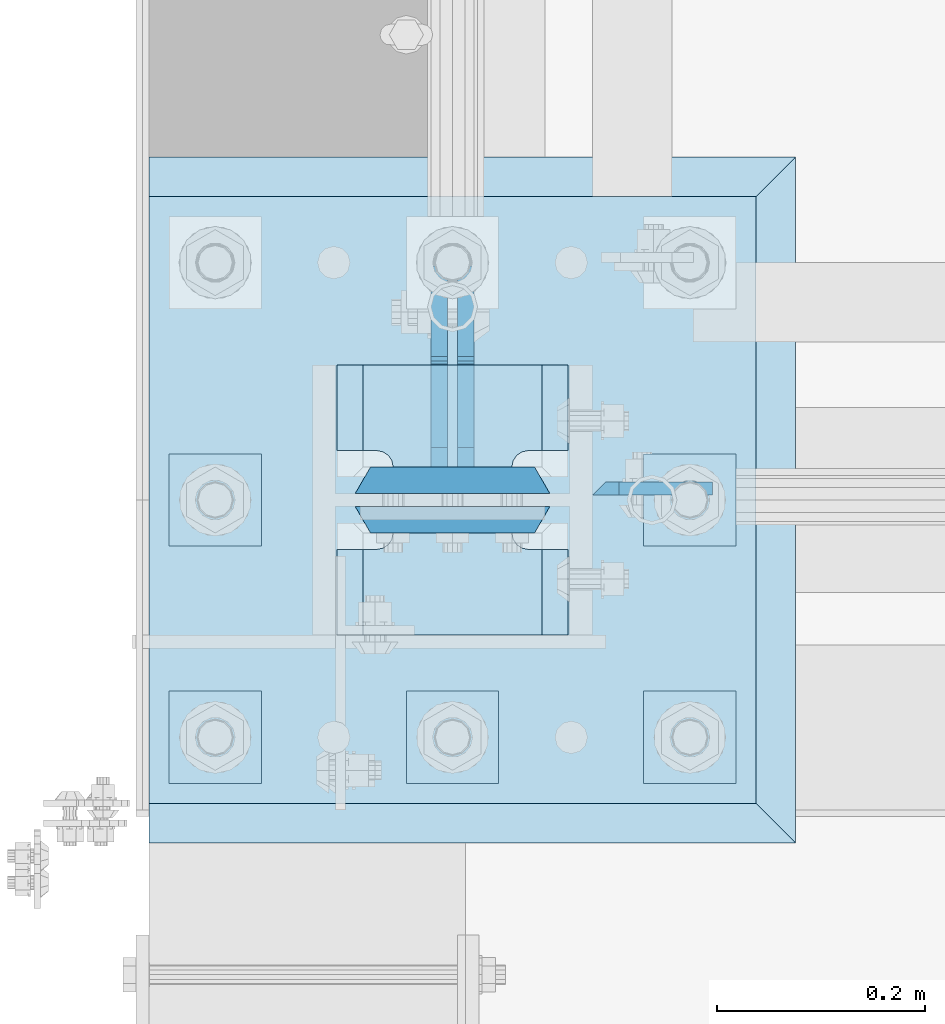
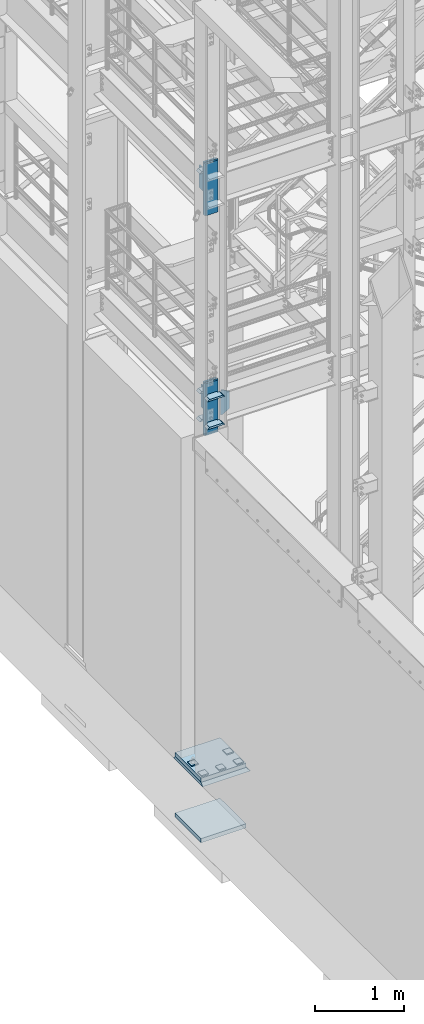
# One storey, part 1422 of 1876: 20 plates, 3 elements without a shape of their own.
"""IFC2X3 building model written with IfcOpenShell, lengths in millimetres."""

from ifc_helpers import new_model, si_unit, frame, origin_with_axes, place, context, subcontext, project, spatial, faceted_brep, material, type_object, element, aggregate, save


model = new_model("IFC2X3")

# Units and contexts
model_context = context("Model", 3, precision=1e-05, world=origin_with_axes())
body_context = subcontext(model_context, "Body", "Model", "MODEL_VIEW")
ifc_project = project(units=[si_unit("LENGTHUNIT", "METRE", prefix="MILLI"), si_unit("AREAUNIT", "SQUARE_METRE"), si_unit("VOLUMEUNIT", "CUBIC_METRE"), si_unit("MASSUNIT", "GRAM", prefix="KILO"), si_unit("TIMEUNIT", "SECOND"), si_unit("PLANEANGLEUNIT", "RADIAN"), si_unit("SOLIDANGLEUNIT", "STERADIAN"), si_unit("THERMODYNAMICTEMPERATUREUNIT", "DEGREE_CELSIUS"), si_unit("LUMINOUSINTENSITYUNIT", "LUMEN")], contexts=[model_context])

# Site, building, storey
site_placement = place(None, origin_with_axes())
site = spatial("IfcSite", under=ifc_project, at=site_placement, CompositionType="ELEMENT")
building_placement = place(site_placement, origin_with_axes())
building = spatial("IfcBuilding", under=site, at=building_placement, Name="Undefined", CompositionType="ELEMENT")
storey_placement = place(building_placement, origin_with_axes())
storey = spatial("IfcBuildingStorey", under=building, at=storey_placement, Name="Undefined", CompositionType="ELEMENT", Elevation=0.0)

# Assembly, plates
assembly_1_placement = place(storey_placement, origin_with_axes())
assembly_1 = element("IfcElementAssembly", 1, at=assembly_1_placement, inside=storey, Name="COLUMN", AssemblyPlace="NOTDEFINED", PredefinedType="RIGID_FRAME")
ifc_material_1 = material(Name="STEEL/A572-50")
plate_type_1 = type_object("IfcPlateType", PredefinedType="NOTDEFINED")
plate_1_placement = place(assembly_1_placement, frame((134.9375, -7100.88799991608, 5094.2875), z_axis=(1.0, 0.0, 0.0), x_axis=(0.0, 0.0, -1.0)))
plate_1 = element("IfcPlate", 2, at=plate_1_placement, type_object=plate_type_1, material=ifc_material_1, Name="PLATE", context=body_context, shape_type="Brep", body=[
    faceted_brep([(0.0, -6.35000000000036, 0.0), (-1.06936913171421e-12, 6.34999999999945, 12.699999332428), (336.549987792969, 6.35000000000036, 12.7), (336.549987792969, -6.35000000000036, 0.0), (336.550000000001, -6.35000000000036, 25.4000000000005), (336.549987792969, 6.35000000000036, 25.4000000000005), (284.53616791736, 6.35000000000036, 115.490600585938), (284.53616791736, -6.35000000000036, 115.490600307004), (52.0138320922852, -6.35000000000036, 115.490599060059), (52.0138320922852, 6.35000000000036, 115.490600585938), (0.0, 6.35000000000036, 25.4000000000005), (0.0, -6.35000000000036, 25.4000000000005)], [[[0, 1, 2, 3]], [[4, 5, 6, 7]], [[8, 9, 10, 11]], [[11, 10, 1, 0]], [[8, 11, 0, 3, 4, 7]], [[9, 8, 7, 6]], [[10, 9, 6, 5, 2, 1]], [[5, 4, 3, 2]]]),
])
plate_type_2 = type_object("IfcPlateType", PredefinedType="NOTDEFINED")
plate_2_placement = place(assembly_1_placement, frame((111.125, -6981.825, 8140.7), z_axis=(-1.0, 0.0, 0.0), x_axis=(0.0, -1.0, 0.0)))
plate_2 = element("IfcPlate", 3, at=plate_2_placement, type_object=plate_type_2, material=ifc_material_1, Name="PLATE", context=body_context, shape_type="Brep", body=[
    faceted_brep([(82.5500030517578, -12.7000000000007, 222.25), (82.5500030517578, 12.7000000000007, 197.150000002177), (0.0, 12.7000000000007, 197.150000002177), (0.0, -12.7000000000007, 222.25), (82.5500030517578, 12.7000000000007, 25.0999999978233), (82.5500030517578, -12.7000000000007, 0.0), (0.0, -12.6999999999998, 0.0), (0.0, 12.7000000000007, 25.0999999978233), (82.5500030517578, 12.7000000000007, 38.0999984741211), (82.5500030517578, -12.7000000000007, 38.0999984741211), (83.7584154731412, -12.7000000000007, 44.1750979629169), (83.7584154731412, 12.7000000000007, 44.1750979629169), (87.1996829004211, -12.7000000000007, 49.3253186254576), (87.1996829004211, 12.7000000000007, 49.3253186254576), (92.349903562962, -12.7000000000007, 52.7665860527377), (92.349903562962, 12.7000000000007, 52.7665860527377), (98.4250030517578, -12.7000000000007, 53.9749984741211), (98.4250030517578, 12.7000000000007, 53.9749984741211), (98.4250030517578, -12.7000000000007, 168.275001525879), (98.4250030517578, 12.7000000000007, 168.275001525879), (92.349903562962, -12.7000000000007, 169.483413947262), (92.349903562962, 12.7000000000007, 169.483413947262), (87.1996829004211, -12.7000000000007, 172.924681374543), (87.1996829004211, 12.7000000000007, 172.924681374543), (83.7584154731412, -12.7000000000007, 178.074902037083), (83.7584154731412, 12.7000000000007, 178.074902037083), (82.5500030517578, -12.7000000000007, 184.150001525879), (82.5500030517578, 12.7000000000007, 184.150001525879)], [[[0, 1, 2, 3]], [[4, 5, 6, 7]], [[8, 9, 5, 4]], [[10, 9, 8, 11]], [[12, 10, 11, 13]], [[14, 12, 13, 15]], [[16, 14, 15, 17]], [[18, 16, 17, 19]], [[20, 18, 19, 21]], [[22, 20, 21, 23]], [[24, 22, 23, 25]], [[26, 24, 25, 27]], [[6, 5, 9, 10, 12, 14, 16, 18, 20, 22, 24, 26, 0, 3]], [[7, 6, 3, 2]], [[27, 25, 23, 21, 19, 17, 15, 13, 11, 8, 4, 7, 2, 1]], [[26, 27, 1, 0]]]),
])
plate_3_placement = place(assembly_1_placement, frame((111.125, -7143.75, 4733.92501220703), z_axis=(-1.0, 0.0, 0.0), x_axis=(0.0, -1.0, 0.0)))
plate_3 = element("IfcPlate", 4, at=plate_3_placement, type_object=plate_type_2, material=ifc_material_1, Name="PLATE", context=body_context, shape_type="Brep", body=[
    faceted_brep([(98.4250030517578, -12.7000000000007, 222.25), (98.4250030517578, 12.7000000000007, 197.150000002177), (15.875, 12.7000000000007, 197.150000002177), (15.875, -12.7000000000007, 222.25), (14.6665875786157, -12.7000000000007, 178.074902037082), (15.875, -12.7000000000007, 184.150001525879), (15.875, 12.7000000000007, 184.150001525879), (14.6665875786157, 12.7000000000007, 178.074902037082), (11.2253201513358, -12.7000000000007, 172.924681374541), (11.2253201513358, 12.7000000000007, 172.924681374541), (6.07509948879488, -12.7000000000007, 169.483413947261), (6.07509948879488, 12.7000000000007, 169.483413947261), (0.0, -12.7000000000007, 168.275001525879), (0.0, 12.7000000000007, 168.275001525879), (0.0, -12.7000000000007, 53.9749984741211), (0.0, 12.7000000000007, 53.9749984741211), (6.07509948879579, -12.7000000000007, 52.7665860527377), (6.07509948879579, 12.7000000000007, 52.7665860527377), (11.2253201513367, -12.7000000000007, 49.3253186254576), (11.2253201513367, 12.7000000000007, 49.3253186254576), (14.6665875786166, -12.7000000000007, 44.1750979629169), (14.6665875786166, 12.7000000000007, 44.1750979629169), (15.875, -12.7000000000007, 38.0999984741211), (15.875, 12.7000000000007, 38.0999984741211), (15.875, 12.7000000000007, 25.0999999978233), (15.875, -12.7000000000007, 0.0), (98.4250030517578, 12.7000000000007, 25.0999999978233), (98.4250030517578, -12.7000000000007, 0.0)], [[[0, 1, 2, 3]], [[4, 5, 6, 7]], [[8, 4, 7, 9]], [[10, 8, 9, 11]], [[12, 10, 11, 13]], [[14, 12, 13, 15]], [[16, 14, 15, 17]], [[18, 16, 17, 19]], [[20, 18, 19, 21]], [[22, 20, 21, 23]], [[22, 23, 24, 25]], [[26, 27, 25, 24]], [[5, 4, 8, 10, 12, 14, 16, 18, 20, 22, 25, 27, 0, 3]], [[6, 5, 3, 2]], [[26, 24, 23, 21, 19, 17, 15, 13, 11, 9, 7, 6, 2, 1]], [[27, 26, 1, 0]]]),
])
plate_4_placement = place(assembly_1_placement, frame((111.125, -7143.75, 5118.1), z_axis=(-1.0, 0.0, 0.0), x_axis=(0.0, -1.0, 0.0)))
plate_4 = element("IfcPlate", 5, at=plate_4_placement, type_object=plate_type_2, material=ifc_material_1, Name="PLATE", context=body_context, shape_type="Brep", body=[
    faceted_brep([(98.4250030517578, -12.7000000000007, 222.25), (98.4250030517578, 12.7000000000007, 197.150000002177), (15.875, 12.7000000000007, 197.150000002177), (15.875, -12.7000000000007, 222.25), (14.6665875786157, -12.7000000000007, 178.074902037082), (15.875, -12.7000000000007, 184.150001525879), (15.875, 12.7000000000007, 184.150001525879), (14.6665875786157, 12.7000000000007, 178.074902037082), (11.2253201513358, -12.7000000000007, 172.924681374541), (11.2253201513358, 12.7000000000007, 172.924681374541), (6.07509948879488, -12.7000000000007, 169.483413947261), (6.07509948879488, 12.7000000000007, 169.483413947261), (0.0, -12.7000000000007, 168.275001525879), (0.0, 12.7000000000007, 168.275001525879), (0.0, -12.7000000000007, 53.9749984741211), (0.0, 12.7000000000007, 53.9749984741211), (6.07509948879579, -12.7000000000007, 52.7665860527377), (6.07509948879579, 12.7000000000007, 52.7665860527377), (11.2253201513367, -12.7000000000007, 49.3253186254576), (11.2253201513367, 12.7000000000007, 49.3253186254576), (14.6665875786166, -12.7000000000007, 44.1750979629169), (14.6665875786166, 12.7000000000007, 44.1750979629169), (15.875, -12.7000000000007, 38.0999984741211), (15.875, 12.7000000000007, 38.0999984741211), (15.875, 12.7000000000007, 25.0999999978233), (15.875, -12.7000000000007, 0.0), (98.4250030517578, 12.7000000000007, 25.0999999978233), (98.4250030517578, -12.7000000000007, 0.0)], [[[0, 1, 2, 3]], [[4, 5, 6, 7]], [[8, 4, 7, 9]], [[10, 8, 9, 11]], [[12, 10, 11, 13]], [[14, 12, 13, 15]], [[16, 14, 15, 17]], [[18, 16, 17, 19]], [[20, 18, 19, 21]], [[22, 20, 21, 23]], [[22, 23, 24, 25]], [[26, 27, 25, 24]], [[5, 4, 8, 10, 12, 14, 16, 18, 20, 22, 25, 27, 0, 3]], [[6, 5, 3, 2]], [[26, 24, 23, 21, 19, 17, 15, 13, 11, 9, 7, 6, 2, 1]], [[27, 26, 1, 0]]]),
])
plate_5_placement = place(assembly_1_placement, frame((111.125, -6981.825, 4733.92501220703), z_axis=(-1.0, 0.0, 0.0), x_axis=(0.0, -1.0, 0.0)))
plate_5 = element("IfcPlate", 6, at=plate_5_placement, type_object=plate_type_2, material=ifc_material_1, Name="PLATE", context=body_context, shape_type="Brep", body=[
    faceted_brep([(82.5500030517578, -12.7000000000007, 222.25), (82.5500030517578, 12.7000000000007, 197.150000002177), (0.0, 12.7000000000007, 197.150000002177), (0.0, -12.7000000000007, 222.25), (82.5500030517578, 12.7000000000007, 25.0999999978233), (82.5500030517578, -12.7000000000007, 0.0), (0.0, -12.6999999999998, 0.0), (0.0, 12.7000000000007, 25.0999999978233), (82.5500030517578, 12.7000000000007, 38.0999984741211), (82.5500030517578, -12.7000000000007, 38.0999984741211), (83.7584154731412, -12.7000000000007, 44.1750979629169), (83.7584154731412, 12.7000000000007, 44.1750979629169), (87.1996829004211, -12.7000000000007, 49.3253186254576), (87.1996829004211, 12.7000000000007, 49.3253186254576), (92.349903562962, -12.7000000000007, 52.7665860527377), (92.349903562962, 12.7000000000007, 52.7665860527377), (98.4250030517578, -12.7000000000007, 53.9749984741211), (98.4250030517578, 12.7000000000007, 53.9749984741211), (98.4250030517578, -12.7000000000007, 168.275001525879), (98.4250030517578, 12.7000000000007, 168.275001525879), (92.349903562962, -12.7000000000007, 169.483413947262), (92.349903562962, 12.7000000000007, 169.483413947262), (87.1996829004211, -12.7000000000007, 172.924681374543), (87.1996829004211, 12.7000000000007, 172.924681374543), (83.7584154731412, -12.7000000000007, 178.074902037083), (83.7584154731412, 12.7000000000007, 178.074902037083), (82.5500030517578, -12.7000000000007, 184.150001525879), (82.5500030517578, 12.7000000000007, 184.150001525879)], [[[0, 1, 2, 3]], [[4, 5, 6, 7]], [[8, 9, 5, 4]], [[10, 9, 8, 11]], [[12, 10, 11, 13]], [[14, 12, 13, 15]], [[16, 14, 15, 17]], [[18, 16, 17, 19]], [[20, 18, 19, 21]], [[22, 20, 21, 23]], [[24, 22, 23, 25]], [[26, 24, 25, 27]], [[6, 5, 9, 10, 12, 14, 16, 18, 20, 22, 24, 26, 0, 3]], [[7, 6, 3, 2]], [[27, 25, 23, 21, 19, 17, 15, 13, 11, 8, 4, 7, 2, 1]], [[26, 27, 1, 0]]]),
])
plate_6_placement = place(assembly_1_placement, frame((111.125, -6981.825, 5118.1), z_axis=(-1.0, 0.0, 0.0), x_axis=(0.0, -1.0, 0.0)))
plate_6 = element("IfcPlate", 7, at=plate_6_placement, type_object=plate_type_2, material=ifc_material_1, Name="PLATE", context=body_context, shape_type="Brep", body=[
    faceted_brep([(82.5500030517578, -12.7000000000007, 222.25), (82.5500030517578, 12.7000000000007, 197.150000002177), (0.0, 12.7000000000007, 197.150000002177), (0.0, -12.7000000000007, 222.25), (82.5500030517578, 12.7000000000007, 25.0999999978233), (82.5500030517578, -12.7000000000007, 0.0), (0.0, -12.6999999999998, 0.0), (0.0, 12.7000000000007, 25.0999999978233), (82.5500030517578, 12.7000000000007, 38.0999984741211), (82.5500030517578, -12.7000000000007, 38.0999984741211), (83.7584154731412, -12.7000000000007, 44.1750979629169), (83.7584154731412, 12.7000000000007, 44.1750979629169), (87.1996829004211, -12.7000000000007, 49.3253186254576), (87.1996829004211, 12.7000000000007, 49.3253186254576), (92.349903562962, -12.7000000000007, 52.7665860527377), (92.349903562962, 12.7000000000007, 52.7665860527377), (98.4250030517578, -12.7000000000007, 53.9749984741211), (98.4250030517578, 12.7000000000007, 53.9749984741211), (98.4250030517578, -12.7000000000007, 168.275001525879), (98.4250030517578, 12.7000000000007, 168.275001525879), (92.349903562962, -12.7000000000007, 169.483413947262), (92.349903562962, 12.7000000000007, 169.483413947262), (87.1996829004211, -12.7000000000007, 172.924681374543), (87.1996829004211, 12.7000000000007, 172.924681374543), (83.7584154731412, -12.7000000000007, 178.074902037083), (83.7584154731412, 12.7000000000007, 178.074902037083), (82.5500030517578, -12.7000000000007, 184.150001525879), (82.5500030517578, 12.7000000000007, 184.150001525879)], [[[0, 1, 2, 3]], [[4, 5, 6, 7]], [[8, 9, 5, 4]], [[10, 9, 8, 11]], [[12, 10, 11, 13]], [[14, 12, 13, 15]], [[16, 14, 15, 17]], [[18, 16, 17, 19]], [[20, 18, 19, 21]], [[22, 20, 21, 23]], [[24, 22, 23, 25]], [[26, 24, 25, 27]], [[6, 5, 9, 10, 12, 14, 16, 18, 20, 22, 24, 26, 0, 3]], [[7, 6, 3, 2]], [[27, 25, 23, 21, 19, 17, 15, 13, 11, 8, 4, 7, 2, 1]], [[26, 27, 1, 0]]]),
])
ifc_material_2 = material(Name="STEEL/A572-GR.50")
plate_type_3 = type_object("IfcPlateType", PredefinedType="NOTDEFINED")
plate_7_placement = place(assembly_1_placement, frame((-93.6625, -7131.05, 8305.8), z_axis=(1.0, 0.0, 0.0), x_axis=(0.0, 0.0, -1.0)))
plate_7 = element("IfcPlate", 8, at=plate_7_placement, type_object=plate_type_3, material=ifc_material_2, Name="PLATE", context=body_context, shape_type="Brep", body=[
    faceted_brep([(0.0, -12.6999999999998, 172.660303166218), (714.375, -12.6999999999998, 172.660303166232), (714.375, 12.6999999999998, 187.324996948242), (0.0, 12.6999999999998, 187.324996948242), (714.375, -12.6999999999998, 14.6646968337647), (714.375, 12.6999999999998, 0.0), (0.0, 12.6999999999998, 0.0), (0.0, -12.6999999999998, 14.6646968337648)], [[[0, 1, 2, 3]], [[2, 1, 4, 5]], [[3, 2, 5, 6]], [[0, 3, 6, 7]], [[1, 0, 7, 4]], [[6, 5, 4, 7]]]),
])
plate_8_placement = place(assembly_1_placement, frame((-93.6625, -7092.95, 8305.8), z_axis=(1.0, 0.0, 0.0), x_axis=(0.0, 0.0, -1.0)))
plate_8 = element("IfcPlate", 9, at=plate_8_placement, type_object=plate_type_3, material=ifc_material_2, Name="PLATE", context=body_context, shape_type="Brep", body=[
    faceted_brep([(0.0, 12.6999999999998, 172.66030316161), (0.0, -12.6999999999998, 187.324996948242), (714.375, -12.6999999999998, 187.324996948242), (714.375, 12.6999999999998, 172.660303161603), (714.375, 12.6999999999998, 14.6646968384017), (0.0, 12.6999999999998, 14.6646968383725), (0.0, -12.6999999999998, 0.0), (714.375, -12.6999999999998, 0.0)], [[[0, 1, 2, 3]], [[0, 3, 4, 5]], [[1, 0, 5, 6]], [[2, 1, 6, 7]], [[3, 2, 7, 4]], [[6, 5, 4, 7]]]),
])
plate_9_placement = place(assembly_1_placement, frame((-93.6625, -7131.05, 5283.2), z_axis=(1.0, 0.0, 0.0), x_axis=(0.0, 0.0, -1.0)))
plate_9 = element("IfcPlate", 10, at=plate_9_placement, type_object=plate_type_3, material=ifc_material_2, Name="PLATE", context=body_context, shape_type="Brep", body=[
    faceted_brep([(0.0, -12.6999999999998, 172.660303166218), (714.375, -12.6999999999998, 172.660303166232), (714.375, 12.6999999999998, 187.324996948242), (0.0, 12.6999999999998, 187.324996948242), (714.375, -12.6999999999998, 14.6646968337647), (714.375, 12.6999999999998, 0.0), (0.0, 12.6999999999998, 0.0), (0.0, -12.6999999999998, 14.6646968337648)], [[[0, 1, 2, 3]], [[2, 1, 4, 5]], [[3, 2, 5, 6]], [[0, 3, 6, 7]], [[1, 0, 7, 4]], [[6, 5, 4, 7]]]),
])
plate_10_placement = place(assembly_1_placement, frame((-93.6625, -7092.95, 5283.2), z_axis=(1.0, 0.0, 0.0), x_axis=(0.0, 0.0, -1.0)))
plate_10 = element("IfcPlate", 11, at=plate_10_placement, type_object=plate_type_3, material=ifc_material_2, Name="PLATE", context=body_context, shape_type="Brep", body=[
    faceted_brep([(0.0, 12.6999999999998, 172.66030316161), (0.0, -12.6999999999998, 187.324996948242), (714.375, -12.6999999999998, 187.324996948242), (714.375, 12.6999999999998, 172.660303161603), (714.375, 12.6999999999998, 14.6646968384017), (0.0, 12.6999999999998, 14.6646968383725), (0.0, -12.6999999999998, 0.0), (714.375, -12.6999999999998, 0.0)], [[[0, 1, 2, 3]], [[0, 3, 4, 5]], [[1, 0, 5, 6]], [[2, 1, 6, 7]], [[3, 2, 7, 4]], [[6, 5, 4, 7]]]),
])
plate_type_4 = type_object("IfcPlateType", PredefinedType="NOTDEFINED")
plate_11_placement = place(assembly_1_placement, frame((-12.6995000839233, -7080.25, 8128.0), z_axis=(0.0, 1.0, 0.0), x_axis=(0.0, 0.0, -1.0)))
plate_11 = element("IfcPlate", 12, at=plate_11_placement, type_object=plate_type_4, material=ifc_material_1, Name="PLATE", context=body_context, shape_type="Brep", body=[
    faceted_brep([(4.8600795180455, -7.9375, 99.3922299225887), (4.8600795180455, 7.9375, 99.3922299225887), (0.0, 7.9375, 98.4255000000012), (0.0, -7.9375, 98.4255000000012), (8.98025598619915, -7.9375, 102.145243823067), (8.98025598619915, 7.9375, 102.145243823067), (11.7332698866776, -7.9375, 106.265420291221), (11.7332698866776, 7.9375, 106.265420291221), (12.6999998092651, -7.9375, 111.125499809266), (12.6999998092651, 7.9375, 111.125499809266), (12.6999998092651, -7.9375, 193.675500000001), (12.7000000839216, 7.9375, 193.675003051758), (19.0499992370605, -7.9375, 0.0), (0.0, -7.9375, 19.0499992370605), (0.0, 7.9375, 19.0499992370605), (19.0499992370605, 7.9375, 0.0), (339.724994659424, -7.9375, 0.0), (339.724994659424, 7.9375, 0.0), (358.774993896484, -7.9375, 19.0499992370605), (358.774993896484, 7.9375, 19.0499992370605), (358.774993896484, 7.9375, 98.4255000000012), (358.775, -7.9375, 98.4255000000012), (330.199986839294, 7.9375, 98.4255000000012), (330.199986839294, -7.9375, 98.4255000000012), (325.339907321249, 7.9375, 99.3922299225887), (325.339907321249, -7.9375, 99.3922299225887), (321.219730853095, 7.9375, 102.145243823067), (321.219730853095, -7.9375, 102.145243823067), (318.466716952616, 7.9375, 106.265420291221), (318.466716952616, -7.9375, 106.265420291221), (317.499987030029, 7.9375, 111.125499809266), (317.499987030029, -7.9375, 111.125499809266), (317.499987030027, -7.9375, 193.675002687786), (317.499987030027, 7.9375, 193.675003051758)], [[[0, 1, 2, 3]], [[4, 5, 1, 0]], [[6, 7, 5, 4]], [[8, 9, 7, 6]], [[10, 11, 9, 8]], [[12, 13, 14, 15]], [[16, 12, 15, 17]], [[18, 16, 17, 19]], [[18, 19, 20, 21]], [[21, 20, 22, 23]], [[23, 22, 24, 25]], [[25, 24, 26, 27]], [[27, 26, 28, 29]], [[29, 28, 30, 31]], [[32, 31, 30, 33]], [[6, 4, 0, 3, 13, 12, 16, 18, 21, 23, 25, 27, 29, 31, 32, 10, 8]], [[14, 13, 3, 2]], [[33, 30, 28, 26, 24, 22, 20, 19, 17, 15, 14, 2, 1, 5, 7, 9, 11]], [[32, 33, 11, 10]]]),
])
plate_12_placement = place(assembly_1_placement, frame((12.6995000839233, -7080.25, 5105.4), z_axis=(0.0, 1.0, 0.0), x_axis=(0.0, 0.0, -1.0)))
plate_12 = element("IfcPlate", 13, at=plate_12_placement, type_object=plate_type_4, material=ifc_material_1, Name="PLATE", context=body_context, shape_type="Brep", body=[
    faceted_brep([(4.86007979270289, -7.9375, 99.3917299225868), (4.86007979270289, 7.9375, 99.3917299225868), (0.0, 7.9375, 98.4249999999993), (0.0, -7.9375, 98.4249999999993), (8.98025626085655, -7.9375, 102.144743823065), (8.98025626085655, 7.9375, 102.144743823065), (11.7332701613341, -7.9375, 106.264920291219), (11.7332701613341, 7.9375, 106.264920291219), (12.7000000839216, -7.9375, 111.124999809264), (12.7000000839216, 7.9375, 111.124999809264), (12.7000000839216, -7.9375, 193.674999999999), (12.7000000839216, 7.9375, 193.675003051758), (19.0499992370605, -7.9375, 0.0), (0.0, -7.9375, 19.0499992370605), (0.0, 7.9375, 19.0499992370605), (19.0499992370605, 7.9375, 0.0), (339.724994659424, -7.9375, 0.0), (339.724994659424, 7.9375, 0.0), (358.774993896484, -7.9375, 19.0499992370605), (358.774993896484, 7.9375, 19.0499992370605), (358.774993896484, 7.9375, 98.4249999999993), (358.774999999998, -7.9375, 98.4249999999993), (330.199986839292, 7.9375, 98.4249999999993), (330.199986839292, -7.9375, 98.4249999999993), (325.339907321249, 7.9375, 99.3917299225868), (325.339907321249, -7.9375, 99.3917299225868), (321.219730853096, 7.9375, 102.144743823065), (321.219730853096, -7.9375, 102.144743823065), (318.466716952618, 7.9375, 106.264920291219), (318.466716952618, -7.9375, 106.264920291219), (317.499987030027, 7.9375, 111.124999809264), (317.499987030027, -7.9375, 111.124999809264), (317.499987030027, -7.9375, 193.675002687786), (317.499987030027, 7.9375, 193.675003051758)], [[[0, 1, 2, 3]], [[4, 5, 1, 0]], [[6, 7, 5, 4]], [[8, 9, 7, 6]], [[10, 11, 9, 8]], [[12, 13, 14, 15]], [[16, 12, 15, 17]], [[18, 16, 17, 19]], [[18, 19, 20, 21]], [[21, 20, 22, 23]], [[23, 22, 24, 25]], [[25, 24, 26, 27]], [[27, 26, 28, 29]], [[29, 28, 30, 31]], [[32, 31, 30, 33]], [[25, 27, 29, 31, 32, 10, 8, 6, 4, 0, 3, 13, 12, 16, 18, 21, 23]], [[14, 13, 3, 2]], [[19, 17, 15, 14, 2, 1, 5, 7, 9, 11, 33, 30, 28, 26, 24, 22, 20]], [[11, 10, 32, 33]]]),
])

# Assembly, plate
assembly_2_placement = place(storey_placement, origin_with_axes())
assembly_2 = element("IfcElementAssembly", 14, at=assembly_2_placement, inside=storey, Name="TEMPLATE", AssemblyPlace="NOTDEFINED", PredefinedType="RIGID_FRAME")
plate_type_5 = type_object("IfcPlateType", PredefinedType="NOTDEFINED")
plate_13_placement = place(assembly_2_placement, frame((-292.1, -7404.1, -765.175), z_axis=(0.0, 1.0, 0.0), x_axis=(1.0, 0.0, 0.0)))
plate_13 = element("IfcPlate", 15, at=plate_13_placement, type_object=plate_type_5, material=ifc_material_1, Name="PLATE", context=body_context, shape_type="Brep", body=[
    faceted_brep([(0.0, -28.575, 0.0), (0.0, -28.575, 584.200012207031), (0.0, 28.575, 584.200012207031), (0.0, 28.575, 0.0), (584.200012207031, -28.575, 584.200012207031), (584.200012207031, 28.575, 584.200012207031), (584.200012207031, -28.575, 0.0), (584.200012207031, 28.575, 0.0)], [[[0, 1, 2, 3]], [[1, 4, 5, 2]], [[4, 6, 7, 5]], [[6, 0, 3, 7]], [[5, 7, 3, 2]], [[6, 4, 1, 0]]]),
])

# Plate
plate_14_placement = place(assembly_1_placement, frame((-292.1, -7404.1, 66.675), z_axis=(0.0, 1.0, 0.0), x_axis=(1.0, 0.0, 0.0)))
plate_14 = element("IfcPlate", 16, at=plate_14_placement, type_object=plate_type_5, material=ifc_material_2, Name="PLATE", context=body_context, shape_type="Brep", body=[
    faceted_brep([(0.0, -28.575, 0.0), (0.0, -28.575, 584.200012207031), (0.0, 28.575, 584.200012207031), (0.0, 28.575, 0.0), (584.200012207031, -28.575, 584.200012207031), (584.200012207031, 28.575, 584.200012207031), (584.200012207031, -28.575, 0.0), (584.200012207031, 28.575, 0.0)], [[[0, 1, 2, 3]], [[1, 4, 5, 2]], [[4, 6, 7, 5]], [[6, 0, 3, 7]], [[5, 7, 3, 2]], [[6, 4, 1, 0]]]),
])

aggregate(assembly_1, [plate_2, plate_7, plate_8, plate_11, plate_3, plate_4, plate_5, plate_6, plate_9, plate_10, plate_12, plate_1, plate_14])

plate_type_6 = type_object("IfcPlateType", PredefinedType="NOTDEFINED")
plate_15_placement = place(assembly_2_placement, frame((184.15, -7296.15, 103.1875), z_axis=(0.0, -1.0, 0.0), x_axis=(1.0, 0.0, 0.0)))
plate_15 = element("IfcPlate", 17, at=plate_15_placement, type_object=plate_type_6, material=ifc_material_1, Name="PLATE WASHER", context=body_context, shape_type="Brep", body=[
    faceted_brep([(0.0, -7.9375, 0.0), (0.0, -7.9375, 88.9000015258789), (0.0, 7.9375, 88.9000015258789), (0.0, 7.9375, 0.0), (88.9000015258789, -7.9375, 88.9000015258789), (88.9000015258789, 7.9375, 88.9000015258789), (88.9000015258789, -7.9375, 0.0), (88.9000015258789, 7.9375, 0.0)], [[[0, 1, 2, 3]], [[1, 4, 5, 2]], [[4, 6, 7, 5]], [[6, 0, 3, 7]], [[5, 7, 3, 2]], [[6, 4, 1, 0]]]),
])

plate_16_placement = place(assembly_2_placement, frame((184.15, -7067.55, 103.1875), z_axis=(0.0, -1.0, 0.0), x_axis=(1.0, 0.0, 0.0)))
plate_16 = element("IfcPlate", 18, at=plate_16_placement, type_object=plate_type_6, material=ifc_material_1, Name="PLATE WASHER", context=body_context, shape_type="Brep", body=[
    faceted_brep([(0.0, -7.9375, 0.0), (0.0, -7.9375, 88.9000015258789), (0.0, 7.9375, 88.9000015258789), (0.0, 7.9375, 0.0), (88.9000015258789, -7.9375, 88.9000015258789), (88.9000015258789, 7.9375, 88.9000015258789), (88.9000015258789, -7.9375, 0.0), (88.9000015258789, 7.9375, 0.0)], [[[0, 1, 2, 3]], [[1, 4, 5, 2]], [[4, 6, 7, 5]], [[6, 0, 3, 7]], [[5, 7, 3, 2]], [[6, 4, 1, 0]]]),
])

plate_17_placement = place(assembly_2_placement, frame((-44.4500000000001, -7296.15, 103.1875), z_axis=(0.0, -1.0, 0.0), x_axis=(1.0, 0.0, 0.0)))
plate_17 = element("IfcPlate", 19, at=plate_17_placement, type_object=plate_type_6, material=ifc_material_1, Name="PLATE WASHER", context=body_context, shape_type="Brep", body=[
    faceted_brep([(0.0, -7.9375, 0.0), (0.0, -7.9375, 88.9000015258789), (0.0, 7.9375, 88.9000015258789), (0.0, 7.9375, 0.0), (88.9000015258789, -7.9375, 88.9000015258789), (88.9000015258789, 7.9375, 88.9000015258789), (88.9000015258789, -7.9375, 0.0), (88.9000015258789, 7.9375, 0.0)], [[[0, 1, 2, 3]], [[1, 4, 5, 2]], [[4, 6, 7, 5]], [[6, 0, 3, 7]], [[5, 7, 3, 2]], [[6, 4, 1, 0]]]),
])

plate_18_placement = place(assembly_2_placement, frame((-273.05, -7296.15, 103.1875), z_axis=(0.0, -1.0, 0.0), x_axis=(1.0, 0.0, 0.0)))
plate_18 = element("IfcPlate", 20, at=plate_18_placement, type_object=plate_type_6, material=ifc_material_1, Name="PLATE WASHER", context=body_context, shape_type="Brep", body=[
    faceted_brep([(0.0, -7.9375, 0.0), (0.0, -7.9375, 88.9000015258789), (0.0, 7.9375, 88.9000015258789), (0.0, 7.9375, 0.0), (88.9000015258789, -7.9375, 88.9000015258789), (88.9000015258789, 7.9375, 88.9000015258789), (88.9000015258789, -7.9375, 0.0), (88.9000015258789, 7.9375, 0.0)], [[[0, 1, 2, 3]], [[1, 4, 5, 2]], [[4, 6, 7, 5]], [[6, 0, 3, 7]], [[5, 7, 3, 2]], [[6, 4, 1, 0]]]),
])

plate_19_placement = place(assembly_2_placement, frame((-273.05, -7067.55, 103.1875), z_axis=(0.0, -1.0, 0.0), x_axis=(1.0, 0.0, 0.0)))
plate_19 = element("IfcPlate", 21, at=plate_19_placement, type_object=plate_type_6, material=ifc_material_1, Name="PLATE WASHER", context=body_context, shape_type="Brep", body=[
    faceted_brep([(0.0, -7.9375, 0.0), (0.0, -7.9375, 88.9000015258789), (0.0, 7.9375, 88.9000015258789), (0.0, 7.9375, 0.0), (88.9000015258789, -7.9375, 88.9000015258789), (88.9000015258789, 7.9375, 88.9000015258789), (88.9000015258789, -7.9375, 0.0), (88.9000015258789, 7.9375, 0.0)], [[[0, 1, 2, 3]], [[1, 4, 5, 2]], [[4, 6, 7, 5]], [[6, 0, 3, 7]], [[5, 7, 3, 2]], [[6, 4, 1, 0]]]),
])

aggregate(assembly_2, [plate_13, plate_15, plate_16, plate_17, plate_18, plate_19])

# Assembly, plate
assembly_3_placement = place(storey_placement, origin_with_axes())
assembly_3 = element("IfcElementAssembly", 22, at=assembly_3_placement, inside=storey, Name="GROUT", AssemblyPlace="NOTDEFINED", PredefinedType="REINFORCEMENT_UNIT")
ifc_material_3 = material(Name="CONCRETE/Concrete_Undefined")
plate_type_7 = type_object("IfcPlateType", PredefinedType="NOTDEFINED")
plate_20_placement = place(assembly_3_placement, frame((-330.2, -7442.2, 19.05), z_axis=(0.0, 1.0, 0.0), x_axis=(1.0, 0.0, 0.0)))
plate_20 = element("IfcPlate", 23, at=plate_20_placement, type_object=plate_type_7, material=ifc_material_3, Name="GROUT", context=body_context, shape_type="Brep", body=[
    faceted_brep([(38.1, 19.0499984741211, 660.400024414062), (38.1, 19.05, 0.0), (38.1000000120275, -19.05, 38.1000000109725), (38.0999999999849, -19.05, 622.299999999983), (622.299999999984, -19.05, 38.1000000000167), (660.400024414062, 19.05, 0.0), (660.400024414062, 19.05, 660.400024414062), (622.299999999984, -19.05, 622.299999999983)], [[[0, 1, 2, 3]], [[4, 5, 6, 7]], [[7, 6, 0, 3]], [[4, 7, 3, 2]], [[5, 4, 2, 1]], [[6, 5, 1, 0]]]),
])
aggregate(assembly_3, [plate_20])

save(model, "model.ifc")
